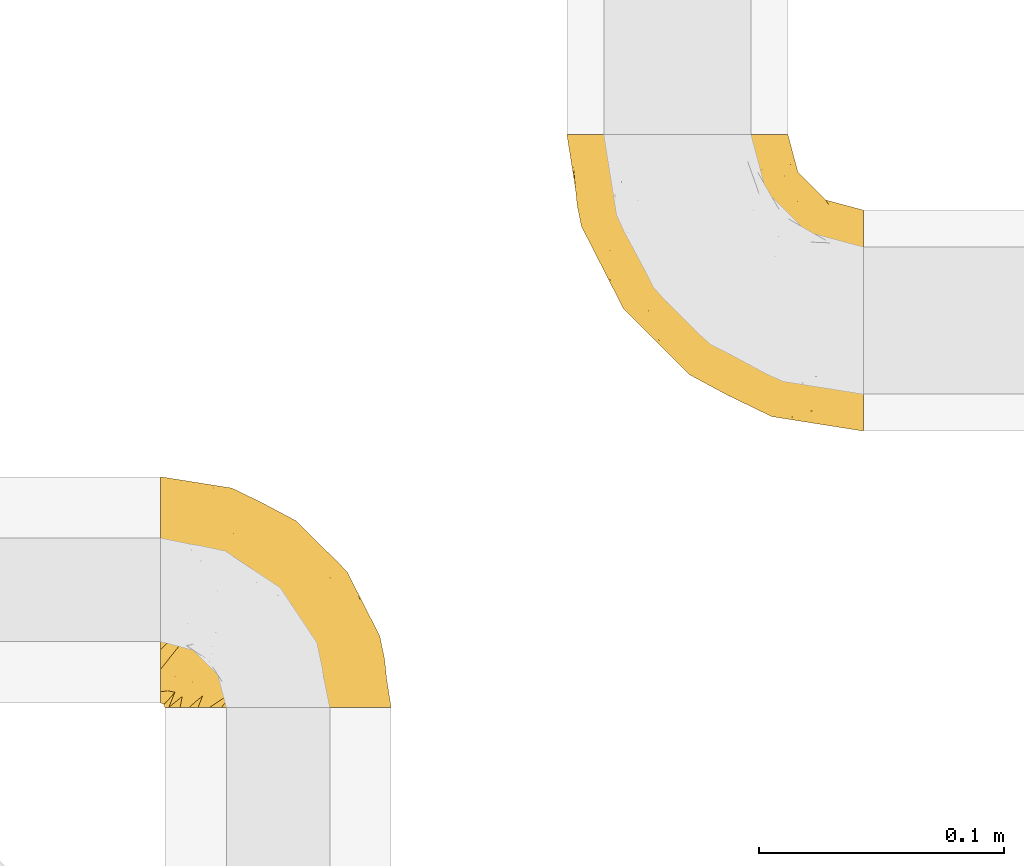
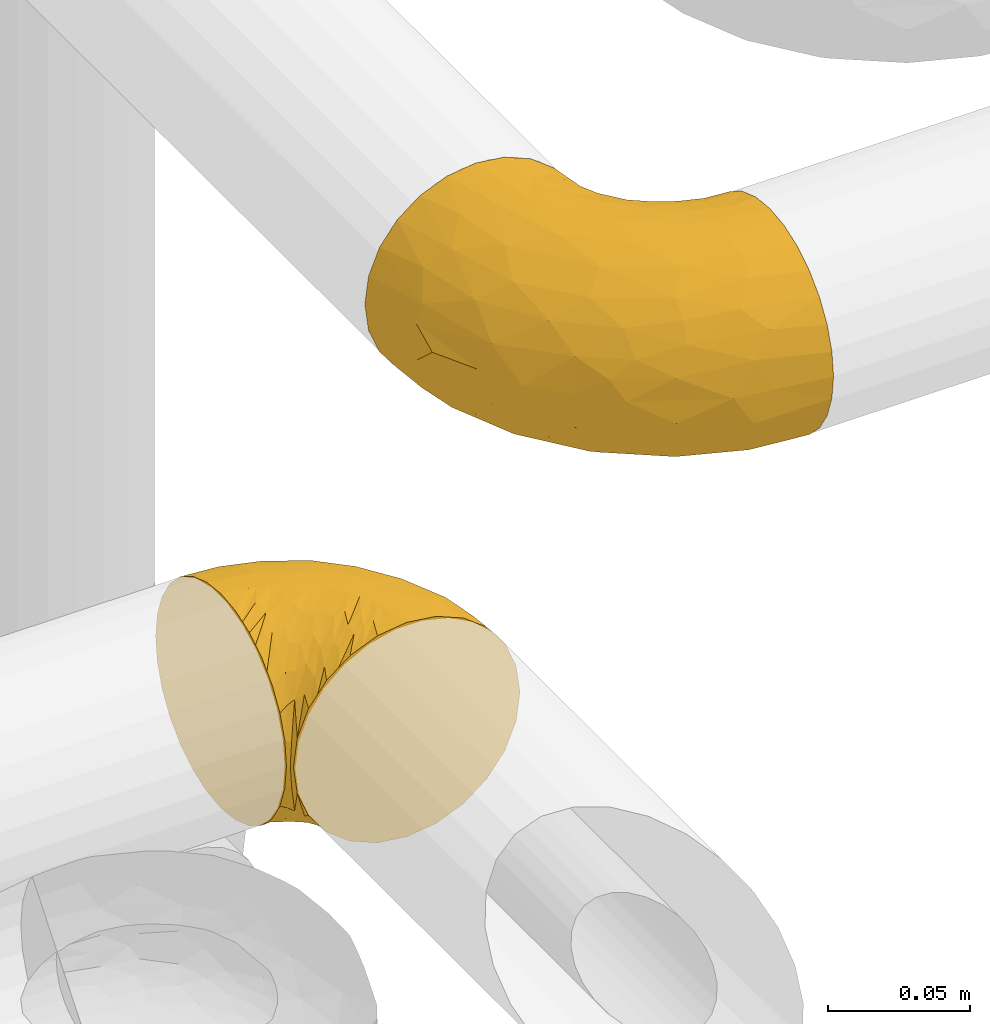
# One storey, part 264 of 827: 2 coverings.
"""IFC2X3 building model written with IfcOpenShell, lengths in millimetres."""

from ifc_helpers import new_model, entity, si_unit, converted_unit, derived_unit, direction, frame, origin, place, context, subcontext, project, spatial, faceted_brep, element, save


model = new_model("IFC2X3")

# Units and contexts
model_context = context("Model", 3, precision=0.01, world=origin(), true_north=direction((6.12303176911189e-17, 1.0)))
body_context = subcontext(model_context, "Body", "Model", "MODEL_VIEW")
ifc_project = project(units=[si_unit("LENGTHUNIT", "METRE", prefix="MILLI"), si_unit("AREAUNIT", "SQUARE_METRE"), si_unit("VOLUMEUNIT", "CUBIC_METRE"), converted_unit("PLANEANGLEUNIT", "DEGREE", entity("IfcRatioMeasure", 0.0174532925199433), si_unit("PLANEANGLEUNIT", "RADIAN"), dimensions=[0, 0, 0, 0, 0, 0, 0]), si_unit("MASSUNIT", "GRAM", prefix="KILO"), derived_unit("MASSDENSITYUNIT", [(si_unit("MASSUNIT", "GRAM", prefix="KILO"), 1), (si_unit("LENGTHUNIT", "METRE"), -3)]), derived_unit("MOMENTOFINERTIAUNIT", [(si_unit("LENGTHUNIT", "METRE"), 4)]), si_unit("TIMEUNIT", "SECOND"), si_unit("FREQUENCYUNIT", "HERTZ"), si_unit("THERMODYNAMICTEMPERATUREUNIT", "DEGREE_CELSIUS"), derived_unit("THERMALTRANSMITTANCEUNIT", [(si_unit("MASSUNIT", "GRAM", prefix="KILO"), 1), (si_unit("THERMODYNAMICTEMPERATUREUNIT", "KELVIN"), -1), (si_unit("TIMEUNIT", "SECOND"), -3)]), derived_unit("VOLUMETRICFLOWRATEUNIT", [(si_unit("LENGTHUNIT", "METRE"), 3), (si_unit("TIMEUNIT", "SECOND"), -1)]), derived_unit("MASSFLOWRATEUNIT", [(si_unit("MASSUNIT", "GRAM", prefix="KILO"), 1), (si_unit("TIMEUNIT", "SECOND"), -1)]), derived_unit("ROTATIONALFREQUENCYUNIT", [(si_unit("TIMEUNIT", "SECOND"), -1)]), si_unit("ELECTRICCURRENTUNIT", "AMPERE"), si_unit("ELECTRICVOLTAGEUNIT", "VOLT"), si_unit("POWERUNIT", "WATT"), si_unit("FORCEUNIT", "NEWTON", prefix="KILO"), si_unit("ILLUMINANCEUNIT", "LUX"), si_unit("LUMINOUSFLUXUNIT", "LUMEN"), si_unit("LUMINOUSINTENSITYUNIT", "CANDELA"), derived_unit("USERDEFINED", [(si_unit("MASSUNIT", "GRAM", prefix="KILO"), -1), (si_unit("LENGTHUNIT", "METRE"), -2), (si_unit("TIMEUNIT", "SECOND"), 3), (si_unit("LUMINOUSFLUXUNIT", "LUMEN"), 1)]), derived_unit("LINEARVELOCITYUNIT", [(si_unit("LENGTHUNIT", "METRE"), 1), (si_unit("TIMEUNIT", "SECOND"), -1)]), si_unit("PRESSUREUNIT", "PASCAL"), derived_unit("USERDEFINED", [(si_unit("LENGTHUNIT", "METRE"), -2), (si_unit("MASSUNIT", "GRAM", prefix="KILO"), 1), (si_unit("TIMEUNIT", "SECOND"), -2)]), derived_unit("LINEARFORCEUNIT", [(si_unit("MASSUNIT", "GRAM", prefix="KILO"), 1), (si_unit("LENGTHUNIT", "METRE"), 1), (si_unit("TIMEUNIT", "SECOND"), -2), (si_unit("LENGTHUNIT", "METRE"), -1)]), derived_unit("PLANARFORCEUNIT", [(si_unit("MASSUNIT", "GRAM", prefix="KILO"), 1), (si_unit("LENGTHUNIT", "METRE"), 1), (si_unit("TIMEUNIT", "SECOND"), -2), (si_unit("LENGTHUNIT", "METRE"), -2)])], contexts=[model_context])

# Site, building, storey
site_placement = place(None, origin())
site = spatial("IfcSite", under=ifc_project, at=site_placement, CompositionType="ELEMENT")
building_placement = place(site_placement, origin())
building = spatial("IfcBuilding", under=site, at=building_placement, CompositionType="ELEMENT")
storey_placement = place(building_placement, frame((0.0, 0.0, 28200.0)))
storey = spatial("IfcBuildingStorey", under=building, at=storey_placement, Name="08", CompositionType="ELEMENT", Elevation=28200.0)

# Coverings
covering_1_placement = place(storey_placement, frame((31256.93, 17331.61, 2952.2)))
element("IfcCovering", 1, at=covering_1_placement, inside=storey, Name=":ADSK_", ObjectType=":ADSK_", PredefinedType="INSULATION", context=body_context, shape_type="Brep", body=[
    faceted_brep([(1.6, 78.41, 83.91), (1.6, 85.72, 76.59), (1.6, 91.22, 67.83), (1.6, 94.64, 58.07), (1.6, 95.8, 47.8), (1.6, 94.64, 37.51), (1.6, 91.22, 27.74), (1.6, 85.71, 18.98), (1.6, 78.39, 11.67), (1.6, 69.63, 6.17), (1.6, 59.87, 2.75), (1.6, 49.6, 1.6), (1.6, 45.45, 2.06), (1.6, 42.38, 2.41), (1.6, 39.31, 2.75), (1.6, 34.43, 4.46), (1.6, 29.54, 6.17), (1.6, 25.16, 8.93), (1.6, 20.78, 11.68), (1.6, 17.13, 15.34), (1.6, 13.47, 19.0), (1.6, 7.97, 27.76), (1.6, 6.26, 32.64), (1.6, 4.55, 37.52), (1.6, 3.4, 47.8), (1.6, 4.55, 58.08), (1.6, 6.26, 62.96), (1.6, 7.97, 67.85), (1.6, 13.48, 76.61), (1.6, 17.14, 80.26), (1.6, 20.8, 83.92), (1.6, 25.18, 86.67), (1.6, 29.56, 89.42), (1.6, 34.44, 91.13), (1.6, 39.32, 92.84), (1.6, 42.39, 93.18), (1.6, 45.45, 93.53), (1.6, 49.6, 94.0), (1.6, 59.88, 92.84), (1.6, 69.65, 89.42), (3.4, 1.6, 47.8), (4.97, 1.6, 35.84), (9.58, 1.6, 24.7), (13.26, 1.6, 19.91), (16.93, 1.6, 15.13), (21.71, 1.6, 11.46), (26.5, 1.6, 7.78), (32.07, 1.6, 5.48), (37.64, 1.6, 3.17), (41.25, 1.6, 2.69), (43.34, 1.6, 2.42), (45.42, 1.6, 2.14), (49.6, 1.6, 1.6), (61.55, 1.6, 3.17), (72.7, 1.6, 7.78), (82.26, 1.6, 15.13), (89.61, 1.6, 24.7), (94.22, 1.6, 35.84), (95.8, 1.6, 47.8), (94.22, 1.6, 59.75), (89.61, 1.6, 70.9), (82.26, 1.6, 80.46), (72.7, 1.6, 87.81), (61.55, 1.6, 92.42), (49.6, 1.6, 94.0), (45.42, 1.6, 93.45), (41.25, 1.6, 92.9), (37.64, 1.6, 92.42), (32.07, 1.6, 90.11), (26.5, 1.6, 87.81), (21.71, 1.6, 84.13), (16.93, 1.6, 80.46), (13.26, 1.6, 75.68), (9.58, 1.6, 70.9), (4.97, 1.6, 59.75), (81.55, 36.81, 71.98), (90.4, 23.28, 63.6), (83.0, 45.8, 59.72), (91.18, 30.7, 47.8), (93.13, 21.2, 55.16), (94.0, 12.96, 47.8), (66.19, 66.19, 63.76), (70.92, 54.51, 72.22), (85.95, 17.98, 74.18), (49.74, 36.69, 92.52), (35.54, 35.54, 94.0), (38.14, 31.64, 94.0), (40.74, 27.75, 94.0), (43.34, 23.86, 94.0), (45.94, 19.96, 94.0), (77.59, 22.8, 82.14), (71.17, 42.67, 80.34), (65.81, 33.21, 87.52), (59.03, 59.45, 79.59), (45.85, 71.5, 78.25), (45.79, 62.66, 85.01), (41.42, 54.5, 90.25), (34.51, 47.57, 93.2), (56.04, 48.81, 87.23), (15.15, 74.98, 85.55), (56.51, 18.7, 93.0), (68.39, 15.75, 89.31), (23.33, 91.17, 61.31), (42.86, 85.28, 56.86), (39.42, 82.58, 68.34), (53.58, 75.78, 65.71), (59.17, 74.98, 56.99), (59.06, 67.27, 72.15), (22.63, 87.38, 70.34), (20.55, 82.04, 78.36), (12.96, 94.0, 47.8), (56.96, 77.8, 47.8), (67.38, 67.38, 47.8), (18.72, 56.2, 93.06), (5.33, 48.85, 94.0), (9.07, 48.11, 94.0), (11.79, 47.57, 94.0), (14.51, 47.03, 94.0), (17.24, 46.48, 94.0), (19.96, 45.94, 94.0), (21.03, 65.78, 89.88), (46.48, 17.24, 94.0), (47.03, 14.51, 94.0), (47.57, 11.79, 94.0), (48.11, 9.07, 94.0), (48.48, 7.2, 94.0), (48.85, 5.33, 94.0), (30.7, 91.18, 47.8), (23.86, 43.34, 94.0), (27.75, 40.74, 94.0), (31.64, 38.14, 94.0), (31.26, 72.73, 83.7), (77.8, 56.96, 47.8), (72.75, 62.23, 55.9), (43.83, 84.49, 47.8), (84.49, 43.83, 47.8), (14.58, 12.05, 81.75), (16.17, 18.95, 86.43), (10.82, 13.02, 79.8), (4.64, 8.34, 69.84), (7.71, 14.63, 79.5), (25.13, 11.09, 88.08), (32.66, 13.66, 91.6), (34.94, 20.08, 92.93), (36.76, 9.61, 92.43), (40.48, 9.48, 93.24), (39.25, 16.1, 93.36), (3.69, 3.42, 57.25), (13.99, 26.63, 89.41), (21.85, 33.72, 92.89), (17.93, 34.77, 92.66), (15.11, 6.75, 79.58), (21.14, 13.31, 86.51), (12.7, 21.11, 86.29), (7.21, 19.94, 83.91), (10.45, 6.04, 73.94), (32.27, 8.67, 90.94), (25.68, 26.11, 91.94), (22.18, 29.3, 91.98), (18.79, 6.32, 82.79), (10.12, 39.92, 93.16), (9.47, 27.05, 88.76), (11.29, 34.4, 91.89), (2.87, 2.87, 47.8), (31.16, 20.92, 92.22), (6.31, 27.43, 88.56), (25.62, 7.54, 87.72), (21.18, 18.45, 88.33), (28.81, 23.88, 92.18), (7.45, 7.77, 71.78), (21.17, 18.43, 7.27), (16.17, 18.93, 9.17), (25.69, 26.08, 3.66), (48.11, 9.07, 1.6), (48.85, 5.33, 1.6), (47.03, 14.51, 1.6), (47.57, 11.79, 1.6), (3.69, 3.42, 38.35), (7.44, 7.76, 23.84), (14.51, 47.03, 1.6), (11.79, 47.57, 1.6), (5.33, 48.85, 1.6), (9.07, 48.11, 1.6), (7.71, 14.62, 16.1), (9.47, 27.03, 6.84), (34.94, 20.08, 2.66), (31.16, 20.92, 3.37), (40.74, 27.75, 1.6), (38.14, 31.64, 1.6), (18.79, 6.33, 12.8), (36.76, 9.61, 3.16), (40.48, 9.48, 2.35), (4.63, 8.33, 25.77), (21.14, 13.3, 9.09), (15.11, 6.74, 16.02), (14.58, 12.04, 13.85), (43.34, 23.86, 1.6), (45.94, 19.96, 1.6), (39.25, 16.1, 2.23), (7.21, 19.93, 11.69), (12.69, 21.1, 9.31), (10.14, 39.92, 2.43), (21.81, 33.68, 2.71), (22.19, 29.28, 3.61), (14.0, 26.62, 6.18), (6.66, 27.87, 6.77), (17.92, 34.75, 2.93), (10.45, 6.04, 21.66), (31.64, 38.14, 1.6), (10.64, 12.79, 16.09), (11.31, 34.41, 3.7), (19.96, 45.94, 1.6), (23.86, 43.34, 1.6), (27.75, 40.74, 1.6), (32.66, 13.66, 3.99), (46.48, 17.24, 1.6), (32.27, 8.67, 4.65), (25.13, 11.09, 7.51), (35.54, 35.54, 1.6), (28.77, 23.83, 3.43), (23.36, 6.03, 9.46), (17.24, 46.48, 1.6), (47.58, 34.52, 2.4), (93.13, 21.2, 40.43), (77.44, 23.82, 13.57), (66.78, 41.32, 11.3), (71.68, 47.62, 18.65), (74.96, 52.66, 27.26), (81.55, 36.81, 23.61), (36.7, 49.75, 3.07), (56.9, 19.07, 2.69), (83.0, 45.8, 35.87), (90.4, 23.28, 31.99), (67.83, 21.35, 6.71), (85.95, 17.98, 21.41), (39.41, 82.57, 27.24), (23.33, 91.17, 34.26), (42.87, 85.27, 38.73), (53.92, 73.89, 26.97), (66.19, 66.19, 31.83), (64.12, 62.43, 23.4), (33.13, 63.53, 6.91), (23.1, 58.45, 3.4), (16.98, 67.16, 5.84), (55.72, 76.72, 35.73), (72.75, 62.22, 39.69), (23.77, 81.54, 17.6), (18.41, 74.8, 10.38), (43.7, 75.83, 20.6), (54.53, 41.45, 5.36), (17.73, 88.2, 24.84), (38.98, 71.6, 13.87), (50.28, 56.23, 9.06), (59.02, 59.44, 15.99)], [[[0, 1, 2, 3, 4, 5, 6, 7, 8, 9, 10, 11, 12, 13, 14, 15, 16, 17, 18, 19, 20, 21, 22, 23, 24, 25, 26, 27, 28, 29, 30, 31, 32, 33, 34, 35, 36, 37, 38, 39]], [[40, 41, 42, 43, 44, 45, 46, 47, 48, 49, 50, 51, 52, 53, 54, 55, 56, 57, 58, 59, 60, 61, 62, 63, 64, 65, 66, 67, 68, 69, 70, 71, 72, 73, 74]], [[75, 76, 77]], [[78, 79, 80]], [[77, 81, 82]], [[76, 75, 83]], [[84, 85, 86, 87, 88, 89]], [[90, 91, 92]], [[76, 60, 59]], [[93, 94, 95]], [[90, 62, 61]], [[83, 61, 60]], [[96, 97, 84]], [[98, 93, 95]], [[0, 39, 99]], [[100, 84, 89]], [[62, 101, 63]], [[2, 102, 3]], [[92, 84, 100]], [[103, 102, 104]], [[103, 105, 106]], [[93, 107, 94]], [[1, 108, 2]], [[92, 101, 90]], [[108, 1, 109]], [[102, 110, 3]], [[93, 82, 107]], [[102, 108, 104]], [[111, 106, 112]], [[109, 0, 99]], [[113, 37, 114, 115, 116, 117, 118, 119]], [[120, 38, 113]], [[100, 89, 121, 122, 123, 124, 125, 126, 64]], [[127, 102, 103]], [[97, 119, 128, 129, 130, 85]], [[99, 120, 131]], [[132, 133, 77]], [[59, 80, 79]], [[1, 0, 109]], [[98, 84, 92]], [[94, 109, 131]], [[120, 39, 38]], [[93, 91, 82]], [[104, 94, 105]], [[97, 113, 119]], [[95, 120, 96]], [[83, 90, 61]], [[91, 93, 98]], [[64, 63, 100]], [[100, 63, 101]], [[77, 76, 79]], [[133, 106, 81]], [[84, 97, 85]], [[113, 96, 120]], [[113, 97, 96]], [[37, 113, 38]], [[110, 102, 127]], [[110, 4, 3]], [[103, 111, 134, 127]], [[90, 75, 91]], [[82, 81, 107]], [[91, 75, 82]], [[77, 82, 75]], [[76, 83, 60]], [[90, 83, 75]], [[105, 107, 81]], [[94, 131, 95]], [[105, 94, 107]], [[109, 94, 104]], [[120, 95, 131]], [[98, 95, 96]], [[84, 98, 96]], [[98, 92, 91]], [[106, 105, 81]], [[103, 104, 105]], [[112, 106, 133]], [[103, 106, 111]], [[112, 133, 132]], [[81, 77, 133]], [[77, 78, 135, 132]], [[120, 99, 39]], [[109, 99, 131]], [[59, 58, 80]], [[59, 79, 76]], [[90, 101, 62]], [[100, 101, 92]], [[2, 108, 102]], [[109, 104, 108]], [[78, 77, 79]], [[136, 137, 138]], [[27, 139, 140]], [[141, 142, 143]], [[144, 145, 121]], [[146, 89, 88]], [[147, 139, 25]], [[148, 149, 150]], [[136, 151, 152]], [[147, 40, 74]], [[24, 147, 25]], [[140, 153, 154]], [[33, 116, 34]], [[73, 151, 155]], [[114, 37, 36, 35, 34, 116, 115]], [[146, 156, 144]], [[157, 85, 130]], [[158, 149, 148]], [[151, 159, 152]], [[117, 33, 160]], [[29, 154, 161]], [[155, 74, 73]], [[162, 128, 119]], [[66, 65, 64, 126, 125, 124, 123, 122, 67]], [[163, 147, 24]], [[27, 140, 28]], [[149, 129, 150]], [[139, 27, 26, 25]], [[68, 144, 69]], [[129, 128, 150]], [[164, 87, 86]], [[130, 129, 149]], [[122, 145, 67]], [[154, 153, 148]], [[162, 119, 160]], [[165, 30, 161]], [[150, 161, 148]], [[128, 162, 150]], [[30, 165, 31]], [[145, 144, 68]], [[89, 146, 144]], [[87, 164, 143]], [[166, 156, 142]], [[88, 87, 143]], [[162, 161, 150]], [[161, 30, 29]], [[154, 29, 28]], [[140, 154, 28]], [[161, 154, 148]], [[140, 137, 153]], [[158, 148, 153]], [[157, 130, 158]], [[153, 137, 158]], [[158, 137, 157]], [[167, 137, 136]], [[168, 85, 157]], [[152, 168, 167]], [[167, 168, 157]], [[164, 152, 141]], [[151, 73, 72]], [[159, 72, 71]], [[88, 142, 146]], [[144, 156, 69]], [[146, 142, 156]], [[70, 166, 71]], [[142, 141, 166]], [[70, 69, 156]], [[141, 159, 71]], [[167, 136, 152]], [[138, 137, 140]], [[155, 136, 169]], [[136, 155, 151]], [[74, 155, 169]], [[152, 159, 141]], [[151, 72, 159]], [[168, 152, 164]], [[137, 167, 157]], [[164, 86, 168]], [[85, 168, 86]], [[116, 33, 117]], [[130, 149, 158]], [[67, 145, 68]], [[121, 89, 144]], [[145, 122, 121]], [[40, 147, 163]], [[169, 147, 74]], [[160, 33, 32]], [[162, 160, 32]], [[160, 119, 118, 117]], [[139, 147, 169]], [[139, 169, 138]], [[162, 32, 31]], [[141, 143, 164]], [[88, 143, 142]], [[71, 166, 141]], [[156, 166, 70]], [[139, 138, 140]], [[169, 136, 138]], [[161, 162, 165]], [[162, 31, 165]], [[170, 171, 172]], [[173, 174, 52, 51, 50, 49, 48, 175, 176]], [[177, 178, 41]], [[179, 15, 180]], [[12, 11, 181, 182, 180, 14, 13]], [[183, 21, 20]], [[19, 18, 184]], [[185, 186, 187]], [[186, 188, 187]], [[43, 189, 44]], [[190, 191, 47]], [[23, 22, 21, 192]], [[193, 194, 195]], [[40, 163, 177]], [[196, 197, 198]], [[24, 23, 177]], [[199, 200, 183]], [[201, 15, 179]], [[47, 46, 190]], [[202, 203, 204]], [[203, 172, 171]], [[205, 206, 184]], [[207, 41, 178]], [[16, 15, 201]], [[14, 180, 15]], [[204, 203, 200]], [[208, 203, 202]], [[163, 24, 177]], [[48, 47, 191]], [[198, 197, 190]], [[199, 184, 204]], [[171, 195, 209]], [[210, 211, 212]], [[206, 212, 213]], [[205, 17, 210]], [[184, 206, 204]], [[210, 212, 206]], [[185, 196, 214]], [[190, 215, 191]], [[216, 45, 214]], [[186, 217, 193]], [[190, 216, 198]], [[199, 20, 19]], [[196, 185, 187]], [[199, 183, 20]], [[184, 199, 19]], [[199, 204, 200]], [[206, 202, 204]], [[171, 183, 200]], [[203, 208, 172]], [[172, 208, 218]], [[171, 200, 203]], [[218, 188, 219]], [[195, 170, 193]], [[217, 186, 185]], [[193, 219, 186]], [[193, 170, 219]], [[207, 194, 42]], [[217, 220, 189]], [[216, 190, 46]], [[214, 196, 198]], [[44, 220, 45]], [[214, 198, 216]], [[216, 46, 45]], [[214, 45, 220]], [[42, 194, 43]], [[189, 193, 217]], [[207, 195, 194]], [[209, 195, 178]], [[41, 207, 42]], [[195, 207, 178]], [[43, 194, 189]], [[193, 189, 194]], [[171, 170, 195]], [[170, 172, 219]], [[218, 219, 172]], [[188, 186, 219]], [[206, 213, 202]], [[208, 202, 213]], [[201, 210, 16]], [[215, 190, 197]], [[215, 175, 191]], [[175, 48, 191]], [[201, 179, 221, 211]], [[210, 201, 211]], [[23, 192, 177]], [[40, 177, 41]], [[183, 209, 192]], [[183, 192, 21]], [[192, 178, 177]], [[205, 18, 17]], [[17, 16, 210]], [[217, 185, 214]], [[189, 220, 44]], [[214, 220, 217]], [[192, 209, 178]], [[171, 209, 183]], [[206, 205, 210]], [[18, 205, 184]], [[222, 197, 196, 187, 188, 218]], [[57, 223, 80]], [[224, 225, 226]], [[226, 227, 228]], [[229, 218, 208, 213, 212, 211]], [[230, 52, 174, 173, 176, 175, 215, 197]], [[231, 232, 228]], [[231, 78, 223]], [[223, 57, 232]], [[224, 233, 225]], [[233, 54, 53]], [[234, 232, 56]], [[56, 55, 234]], [[234, 224, 228]], [[235, 236, 237]], [[224, 55, 54]], [[238, 239, 240]], [[52, 230, 53]], [[241, 242, 243]], [[239, 244, 245]], [[11, 10, 242]], [[236, 6, 5]], [[7, 246, 8]], [[8, 247, 9]], [[238, 248, 235]], [[222, 229, 249]], [[242, 211, 221, 179, 180, 182, 181, 11]], [[233, 53, 230]], [[111, 112, 244]], [[250, 6, 236]], [[247, 251, 241]], [[6, 250, 7]], [[127, 236, 110]], [[249, 229, 252]], [[247, 8, 246]], [[235, 246, 250]], [[236, 5, 110]], [[235, 244, 238]], [[237, 236, 127]], [[243, 9, 247]], [[252, 229, 241]], [[56, 232, 57]], [[222, 230, 197]], [[225, 249, 252]], [[249, 233, 230]], [[54, 233, 224]], [[231, 228, 227]], [[245, 132, 231]], [[249, 225, 233]], [[226, 225, 253]], [[235, 250, 236]], [[246, 7, 250]], [[251, 247, 246]], [[243, 247, 241]], [[248, 246, 235]], [[252, 251, 253]], [[229, 222, 218]], [[230, 222, 249]], [[5, 4, 110]], [[237, 127, 134, 111]], [[238, 244, 239]], [[224, 234, 55]], [[232, 234, 228]], [[242, 241, 229]], [[10, 9, 243]], [[211, 242, 229]], [[10, 243, 242]], [[80, 223, 78]], [[80, 58, 57]], [[231, 223, 232]], [[227, 240, 239]], [[224, 226, 228]], [[240, 226, 253]], [[227, 239, 245]], [[226, 240, 227]], [[251, 248, 253]], [[240, 253, 248]], [[244, 235, 237]], [[237, 111, 244]], [[132, 245, 112]], [[112, 245, 244]], [[135, 78, 231, 132]], [[227, 245, 231]], [[248, 238, 240]], [[246, 248, 251]], [[251, 252, 241]], [[225, 252, 253]]]),
])
covering_2_placement = place(storey_placement, frame((31422.92, 17444.46, 2953.25)))
element("IfcCovering", 2, at=covering_2_placement, inside=storey, Name=":ADSK_", ObjectType=":ADSK_", PredefinedType="INSULATION", context=body_context, shape_type="Brep", body=[
    faceted_brep([(122.75, 36.69, 90.76), (122.75, 27.15, 87.42), (122.75, 18.59, 82.04), (122.75, 11.44, 74.89), (122.75, 6.06, 66.33), (122.75, 2.73, 56.79), (122.75, 1.6, 46.75), (122.75, 2.73, 36.69), (122.75, 6.07, 27.15), (122.75, 11.45, 18.59), (122.75, 18.6, 11.44), (122.75, 27.16, 6.06), (122.75, 36.7, 2.73), (122.75, 46.75, 1.6), (122.75, 56.8, 2.73), (122.75, 66.34, 6.07), (122.75, 74.9, 11.45), (122.75, 82.05, 18.6), (122.75, 87.43, 27.16), (122.75, 90.76, 36.7), (122.75, 91.9, 46.75), (122.75, 90.76, 56.8), (122.75, 87.42, 66.34), (122.75, 82.04, 74.9), (122.75, 74.89, 82.05), (122.75, 66.33, 87.43), (122.75, 56.79, 90.76), (122.75, 46.75, 91.9), (90.36, 122.75, 35.06), (85.85, 122.75, 24.17), (78.67, 122.75, 14.82), (69.32, 122.75, 7.64), (58.43, 122.75, 3.13), (46.75, 122.75, 1.6), (35.06, 122.75, 3.13), (24.17, 122.75, 7.64), (14.82, 122.75, 14.82), (7.64, 122.75, 24.17), (3.13, 122.75, 35.06), (1.6, 122.75, 46.75), (3.13, 122.75, 58.43), (7.64, 122.75, 69.32), (14.82, 122.75, 78.67), (24.17, 122.75, 85.85), (35.06, 122.75, 90.36), (46.75, 122.75, 91.9), (58.43, 122.75, 90.36), (69.32, 122.75, 85.85), (78.67, 122.75, 78.67), (85.85, 122.75, 69.32), (90.36, 122.75, 58.43), (91.9, 122.75, 46.75), (51.54, 24.73, 46.75), (47.17, 29.08, 55.2), (38.13, 38.13, 46.75), (7.52, 85.31, 46.75), (5.85, 93.59, 54.53), (5.11, 100.54, 46.75), (19.2, 63.54, 59.63), (38.98, 38.98, 62.07), (35.02, 50.71, 71.86), (8.21, 93.33, 62.65), (19.28, 75.2, 71.33), (12.19, 100.46, 72.93), (101.39, 41.6, 91.2), (34.43, 80.86, 86.31), (20.95, 94.87, 80.89), (30.74, 67.96, 79.49), (72.93, 52.16, 90.68), (56.64, 52.1, 86.84), (80.81, 36.74, 87.38), (93.43, 17.11, 76.87), (100.76, 23.24, 83.73), (74.27, 29.18, 81.03), (93.66, 52.53, 91.9), (81.33, 60.77, 91.9), (69.01, 69.01, 91.9), (40.87, 100.68, 91.03), (29.38, 103.79, 87.58), (67.05, 16.37, 56.52), (85.31, 7.52, 46.75), (93.68, 7.31, 60.4), (52.53, 93.66, 91.9), (50.71, 102.83, 91.9), (48.88, 112.01, 91.9), (72.77, 18.17, 67.87), (51.21, 71.97, 90.35), (101.18, 9.83, 69.57), (100.54, 5.11, 46.75), (48.74, 45.97, 79.91), (112.01, 48.88, 91.9), (102.83, 50.71, 91.9), (73.88, 22.83, 74.99), (24.73, 51.54, 46.75), (60.77, 81.33, 91.9), (103.08, 31.74, 88.53), (54.8, 32.48, 72.65), (16.13, 68.42, 46.75), (55.92, 25.33, 62.97), (68.42, 16.13, 46.75), (104.98, 92.29, 66.2), (108.58, 94.12, 56.6), (98.21, 100.97, 59.89), (61.56, 95.91, 90.95), (60.69, 107.9, 90.22), (100.0, 87.24, 76.64), (95.88, 95.46, 71.58), (90.81, 90.41, 79.99), (84.88, 74.17, 89.54), (73.29, 83.77, 89.97), (113.4, 76.72, 81.32), (109.8, 84.44, 74.56), (102.13, 76.42, 84.15), (67.29, 90.07, 90.37), (70.34, 99.69, 87.82), (95.15, 61.74, 90.98), (105.49, 58.16, 90.96), (71.5, 112.6, 85.14), (92.87, 110.45, 58.11), (96.03, 107.32, 46.75), (81.34, 108.48, 78.39), (107.44, 66.63, 88.22), (88.36, 115.23, 66.06), (90.43, 105.79, 68.6), (114.37, 89.6, 63.78), (98.41, 69.39, 88.42), (88.73, 66.99, 90.61), (76.89, 102.31, 83.8), (86.08, 99.54, 77.98), (112.64, 55.27, 91.22), (94.21, 82.03, 83.46), (112.22, 94.71, 46.75), (107.32, 96.03, 46.75), (79.95, 94.11, 84.66), (84.51, 84.21, 86.33), (101.67, 101.67, 46.75), (94.71, 112.22, 46.75), (81.34, 108.48, 15.1), (76.89, 102.31, 9.69), (86.08, 99.54, 15.52), (79.96, 94.11, 8.83), (92.87, 110.46, 35.39), (113.41, 76.74, 12.18), (102.83, 50.71, 1.6), (105.5, 58.17, 2.53), (112.64, 55.27, 2.27), (108.58, 94.12, 36.9), (104.98, 92.3, 27.31), (98.2, 100.98, 33.62), (98.4, 69.41, 5.07), (102.13, 76.44, 9.36), (107.44, 66.65, 5.27), (88.36, 115.24, 27.43), (50.71, 102.83, 1.6), (48.88, 112.01, 1.6), (94.22, 82.05, 10.05), (100.01, 87.25, 16.87), (71.5, 112.6, 8.35), (60.69, 107.9, 3.27), (52.53, 93.66, 1.6), (95.89, 95.48, 21.94), (114.37, 89.6, 29.72), (81.33, 60.77, 1.6), (69.01, 69.01, 1.6), (84.88, 74.17, 3.96), (112.01, 48.88, 1.6), (109.8, 84.45, 18.95), (61.56, 95.91, 2.54), (67.29, 90.07, 3.12), (60.77, 81.33, 1.6), (95.14, 61.75, 2.51), (73.29, 83.77, 3.52), (84.53, 84.21, 7.17), (93.66, 52.53, 1.6), (90.82, 90.42, 13.52), (88.73, 67.0, 2.88), (70.34, 99.69, 5.67), (90.43, 105.8, 24.89), (20.95, 94.87, 12.6), (34.43, 80.86, 7.18), (30.74, 67.95, 14.0), (19.29, 75.17, 22.16), (35.07, 50.65, 21.61), (51.21, 71.97, 3.14), (56.67, 52.08, 6.65), (54.85, 32.46, 20.82), (38.98, 38.98, 31.41), (29.38, 103.79, 5.91), (40.87, 100.68, 2.46), (19.2, 63.54, 33.87), (8.21, 93.32, 30.84), (5.85, 93.59, 38.96), (12.19, 100.44, 20.56), (72.93, 52.17, 2.81), (80.83, 36.75, 6.1), (101.39, 41.61, 2.29), (93.69, 7.31, 33.08), (93.43, 17.12, 16.61), (67.04, 16.37, 36.96), (100.76, 23.26, 9.75), (72.78, 18.17, 25.61), (55.93, 25.33, 30.5), (101.18, 9.84, 23.91), (74.27, 29.19, 12.45), (73.89, 22.84, 18.49), (103.09, 31.75, 4.96), (48.78, 45.96, 13.56), (47.19, 29.07, 38.28)], [[[0, 1, 2, 3, 4, 5, 6, 7, 8, 9, 10, 11, 12, 13, 14, 15, 16, 17, 18, 19, 20, 21, 22, 23, 24, 25, 26, 27]], [[28, 29, 30, 31, 32, 33, 34, 35, 36, 37, 38, 39, 40, 41, 42, 43, 44, 45, 46, 47, 48, 49, 50, 51]], [[52, 53, 54]], [[55, 56, 57]], [[58, 59, 60]], [[61, 62, 63]], [[27, 64, 0]], [[65, 66, 67]], [[41, 40, 61]], [[68, 69, 70]], [[66, 43, 42]], [[63, 42, 41]], [[71, 72, 73]], [[72, 2, 1]], [[68, 74, 75, 76]], [[45, 44, 77]], [[43, 78, 44]], [[79, 80, 81]], [[77, 82, 83, 84, 45]], [[79, 81, 85]], [[71, 2, 72]], [[65, 86, 77]], [[4, 81, 5]], [[66, 65, 78]], [[4, 3, 87]], [[81, 88, 5]], [[63, 66, 42]], [[68, 70, 64]], [[67, 60, 89]], [[71, 3, 2]], [[64, 27, 90, 91, 74]], [[92, 71, 73]], [[40, 57, 56]], [[59, 93, 54]], [[86, 76, 94, 82]], [[1, 0, 95]], [[58, 62, 61]], [[60, 96, 89]], [[85, 81, 87]], [[56, 97, 58]], [[65, 67, 69]], [[87, 81, 4]], [[67, 89, 69]], [[61, 63, 41]], [[95, 72, 1]], [[73, 72, 70]], [[69, 73, 70]], [[73, 89, 96]], [[3, 71, 87]], [[85, 87, 71]], [[58, 61, 56]], [[59, 58, 93]], [[76, 86, 68]], [[69, 89, 73]], [[68, 86, 69]], [[65, 69, 86]], [[68, 64, 74]], [[95, 64, 70]], [[98, 79, 85]], [[79, 52, 99, 80]], [[66, 62, 67]], [[62, 58, 60]], [[62, 60, 67]], [[59, 98, 96]], [[59, 96, 60]], [[96, 85, 92]], [[88, 81, 80]], [[88, 6, 5]], [[66, 63, 62]], [[64, 95, 0]], [[72, 95, 70]], [[77, 44, 78]], [[86, 82, 77]], [[40, 39, 57]], [[96, 98, 85]], [[40, 56, 61]], [[66, 78, 43]], [[77, 78, 65]], [[79, 98, 53]], [[96, 92, 73]], [[85, 71, 92]], [[97, 56, 55]], [[97, 93, 58]], [[53, 98, 59]], [[54, 53, 59]], [[79, 53, 52]], [[100, 101, 102]], [[46, 45, 84, 83]], [[103, 104, 82]], [[82, 104, 83]], [[105, 106, 107]], [[108, 109, 76]], [[110, 111, 112]], [[103, 113, 114]], [[115, 74, 116]], [[48, 47, 117]], [[118, 102, 119]], [[49, 48, 120]], [[74, 91, 116]], [[116, 121, 115]], [[49, 122, 50]], [[123, 106, 102]], [[124, 111, 22]], [[125, 126, 115]], [[23, 22, 111]], [[24, 110, 121]], [[120, 127, 128]], [[90, 26, 129]], [[27, 26, 90]], [[121, 125, 115]], [[24, 121, 25]], [[130, 105, 107]], [[129, 25, 116]], [[21, 20, 131]], [[120, 123, 122]], [[112, 105, 130]], [[50, 118, 51]], [[21, 124, 22]], [[101, 131, 132]], [[117, 120, 48]], [[24, 23, 110]], [[127, 114, 133]], [[75, 108, 76]], [[107, 134, 130]], [[133, 114, 113]], [[129, 116, 91]], [[25, 121, 116]], [[121, 112, 125]], [[75, 74, 115]], [[101, 135, 102]], [[131, 101, 21]], [[101, 100, 124]], [[128, 127, 133]], [[119, 136, 51, 118]], [[104, 47, 46]], [[83, 104, 46]], [[117, 104, 114]], [[101, 124, 21]], [[111, 124, 100]], [[102, 118, 123]], [[133, 134, 107]], [[111, 110, 23]], [[114, 104, 103]], [[94, 76, 109]], [[121, 110, 112]], [[122, 118, 50]], [[134, 109, 108]], [[133, 107, 128]], [[112, 108, 125]], [[126, 125, 108]], [[108, 75, 126]], [[75, 115, 126]], [[109, 134, 133]], [[130, 108, 112]], [[108, 130, 134]], [[105, 112, 111]], [[111, 100, 105]], [[106, 105, 100]], [[102, 106, 100]], [[128, 106, 123]], [[90, 129, 91]], [[25, 129, 26]], [[104, 117, 47]], [[117, 114, 127]], [[82, 94, 103]], [[113, 94, 109]], [[94, 113, 103]], [[133, 113, 109]], [[106, 128, 107]], [[123, 120, 128]], [[120, 122, 49]], [[118, 122, 123]], [[135, 101, 132]], [[135, 119, 102]], [[117, 127, 120]], [[30, 29, 137]], [[138, 139, 140]], [[51, 136, 119, 141]], [[142, 17, 16]], [[143, 144, 145]], [[146, 147, 148]], [[149, 150, 151]], [[152, 29, 28]], [[33, 32, 153, 154]], [[150, 155, 156]], [[157, 31, 30]], [[153, 158, 159]], [[29, 152, 137]], [[148, 141, 119]], [[156, 160, 147]], [[148, 135, 146]], [[137, 138, 157]], [[19, 161, 146]], [[162, 163, 164]], [[14, 13, 165]], [[153, 32, 158]], [[147, 161, 166]], [[18, 17, 166]], [[167, 168, 169]], [[166, 150, 156]], [[151, 150, 142]], [[151, 170, 149]], [[151, 16, 15]], [[171, 140, 172]], [[165, 143, 145]], [[173, 170, 144]], [[142, 166, 17]], [[19, 131, 20]], [[144, 170, 151]], [[18, 161, 19]], [[173, 144, 143]], [[140, 139, 174]], [[171, 164, 163]], [[164, 172, 155]], [[151, 15, 144]], [[145, 15, 14]], [[173, 162, 170]], [[149, 175, 164]], [[19, 146, 131]], [[132, 131, 146]], [[160, 148, 147]], [[159, 158, 167]], [[135, 132, 146]], [[158, 32, 31]], [[157, 158, 31]], [[167, 158, 176]], [[166, 161, 18]], [[146, 161, 147]], [[148, 177, 141]], [[171, 168, 140]], [[171, 163, 169]], [[151, 142, 16]], [[166, 142, 150]], [[152, 141, 177]], [[51, 141, 28]], [[138, 140, 176]], [[172, 140, 174]], [[175, 149, 170]], [[164, 150, 149]], [[170, 162, 175]], [[162, 164, 175]], [[155, 172, 174]], [[171, 172, 164]], [[155, 174, 156]], [[164, 155, 150]], [[160, 156, 174]], [[147, 166, 156]], [[139, 160, 174]], [[148, 160, 177]], [[15, 145, 144]], [[165, 145, 14]], [[137, 157, 30]], [[158, 157, 176]], [[168, 167, 176]], [[169, 159, 167]], [[140, 168, 176]], [[169, 168, 171]], [[137, 177, 139]], [[160, 139, 177]], [[141, 152, 28]], [[137, 152, 177]], [[148, 119, 135]], [[157, 138, 176]], [[139, 138, 137]], [[178, 179, 180]], [[181, 180, 182]], [[179, 183, 184]], [[185, 186, 182]], [[187, 188, 179]], [[188, 33, 154, 153, 159]], [[181, 189, 190]], [[35, 34, 187]], [[191, 38, 190]], [[192, 178, 181]], [[179, 184, 180]], [[192, 190, 37]], [[37, 190, 38]], [[36, 35, 178]], [[54, 93, 186]], [[35, 187, 178]], [[193, 194, 184]], [[195, 173, 143, 165, 13]], [[195, 193, 173]], [[193, 163, 162, 173]], [[13, 12, 195]], [[8, 7, 196]], [[9, 197, 10]], [[198, 80, 99, 52]], [[196, 7, 88]], [[197, 199, 10]], [[182, 189, 181]], [[200, 198, 201]], [[200, 196, 198]], [[9, 8, 202]], [[194, 199, 203]], [[192, 37, 36]], [[80, 196, 88]], [[183, 159, 169, 163]], [[188, 34, 33]], [[202, 200, 197]], [[185, 203, 204]], [[202, 8, 196]], [[10, 199, 11]], [[12, 11, 205]], [[38, 191, 57]], [[189, 97, 191]], [[203, 199, 197]], [[205, 199, 194]], [[204, 203, 197]], [[184, 203, 206]], [[200, 202, 196]], [[197, 9, 202]], [[207, 54, 186]], [[97, 55, 191]], [[194, 203, 184]], [[183, 163, 193]], [[184, 206, 180]], [[183, 193, 184]], [[205, 195, 12]], [[193, 195, 194]], [[80, 198, 196]], [[207, 186, 201]], [[182, 180, 206]], [[181, 178, 180]], [[185, 182, 206]], [[182, 186, 189]], [[203, 185, 206]], [[185, 200, 201]], [[7, 6, 88]], [[178, 192, 36]], [[190, 192, 181]], [[199, 205, 11]], [[195, 205, 194]], [[159, 183, 188]], [[179, 188, 183]], [[57, 191, 55]], [[57, 39, 38]], [[189, 191, 190]], [[188, 187, 34]], [[178, 187, 179]], [[186, 93, 189]], [[197, 200, 204]], [[185, 204, 200]], [[189, 93, 97]], [[207, 198, 52]], [[185, 201, 186]], [[198, 207, 201]], [[54, 207, 52]]]),
])

save(model, "model.ifc")
